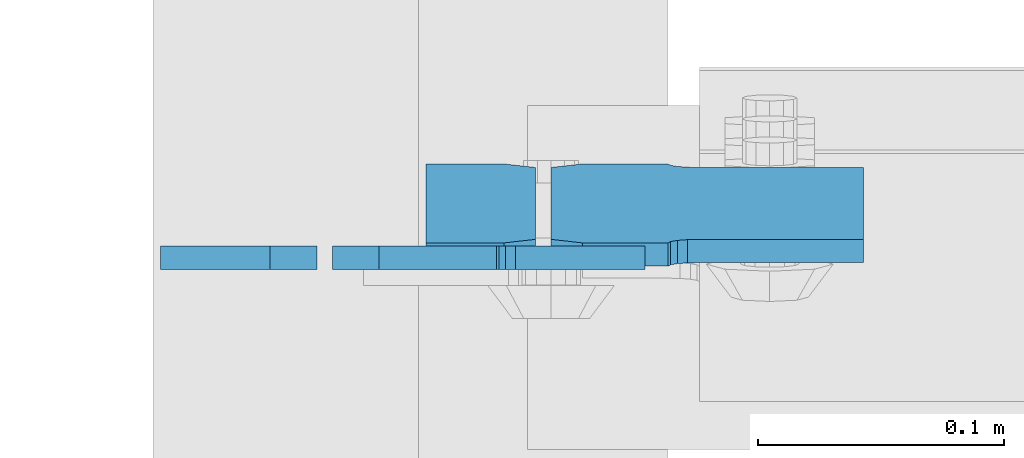
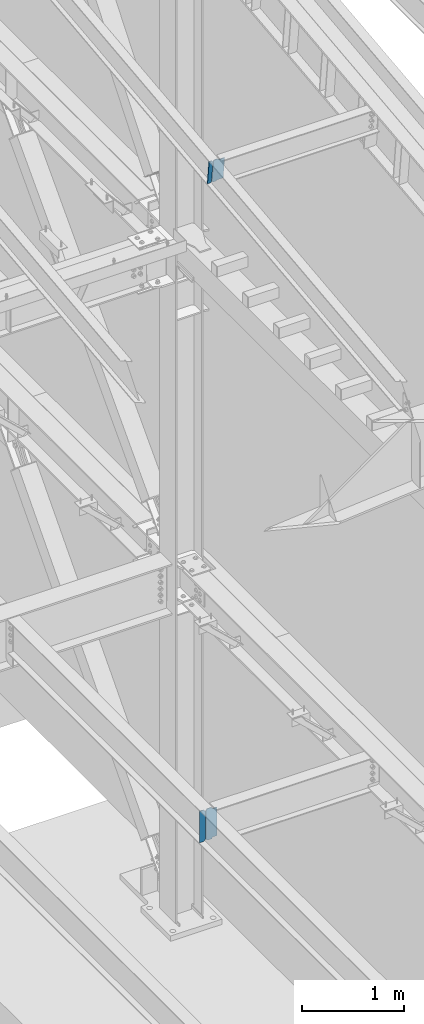
# One storey, part 1036 of 1179: 4 plates, 2 elements without a shape of their own.
"""IFC2X3 building model written with IfcOpenShell, lengths in millimetres."""

from ifc_helpers import new_model, si_unit, frame, origin_with_axes, place, context, subcontext, project, spatial, faceted_brep, material, type_object, element, aggregate, save


model = new_model("IFC2X3")

# Units and contexts
model_context = context("Model", 3, precision=1e-05, world=origin_with_axes())
body_context = subcontext(model_context, "Body", "Model", "MODEL_VIEW")
ifc_project = project(units=[si_unit("LENGTHUNIT", "METRE", prefix="MILLI"), si_unit("AREAUNIT", "SQUARE_METRE"), si_unit("VOLUMEUNIT", "CUBIC_METRE"), si_unit("MASSUNIT", "GRAM", prefix="KILO"), si_unit("TIMEUNIT", "SECOND"), si_unit("PLANEANGLEUNIT", "RADIAN"), si_unit("SOLIDANGLEUNIT", "STERADIAN"), si_unit("THERMODYNAMICTEMPERATUREUNIT", "DEGREE_CELSIUS"), si_unit("LUMINOUSINTENSITYUNIT", "LUMEN")], contexts=[model_context])

# Site, building, storey
site_placement = place(None, origin_with_axes())
site = spatial("IfcSite", under=ifc_project, at=site_placement, CompositionType="ELEMENT")
building_placement = place(site_placement, origin_with_axes())
building = spatial("IfcBuilding", under=site, at=building_placement, Name="Undefined", CompositionType="ELEMENT")
storey_placement = place(building_placement, origin_with_axes())
storey = spatial("IfcBuildingStorey", under=building, at=storey_placement, Name="Undefined", CompositionType="ELEMENT", Elevation=0.0)

# Assembly, plates
assembly_1_placement = place(storey_placement, origin_with_axes())
assembly_1 = element("IfcElementAssembly", 1, at=assembly_1_placement, inside=storey, Name="BEAM", AssemblyPlace="NOTDEFINED", PredefinedType="RIGID_FRAME")
ifc_material = material(Name="STEEL/A36")
plate_type_1 = type_object("IfcPlateType", PredefinedType="NOTDEFINED")
plate_1_placement = place(assembly_1_placement, frame((22412.325, 23180.8083222494, 11565.9313643572), z_axis=(0.0, -0.112284087038017, 0.993676146336441), x_axis=(-1.0, 0.0, 0.0)))
plate_1 = element("IfcPlate", 2, at=plate_1_placement, type_object=plate_type_1, material=ifc_material, Name="PLATE", context=body_context, shape_type="Brep", body=[
    faceted_brep([(-2.72848410531878e-12, -4.76249999998981, 12.6999998092615), (-5.54791768081486e-11, -4.76249999988249, 273.050000190095), (-5.54791768081486e-11, 4.76250000010987, 273.050000190089), (-2.72848410531878e-12, 4.76250000000437, 12.699999809256), (12.6999998092069, -4.76249999987886, 285.749999999351), (12.6999998092069, 4.76250000011532, 285.749999999349), (44.450000005796, -4.76249999988067, 285.749999998694), (44.450000005796, 4.7625000001135, 285.74999999869), (44.4500000000007, -4.76250000000073, 0.0), (44.4500000000007, 4.76250000000073, 0.0), (12.6999998092651, -4.76249999999527, 1.81898940354586e-12), (12.6999998092651, 4.76250000000073, 0.0)], [[[0, 1, 2, 3]], [[1, 4, 5, 2]], [[4, 6, 7, 5]], [[6, 8, 9, 7]], [[8, 10, 11, 9]], [[10, 0, 3, 11]], [[5, 7, 9, 11, 3, 2]], [[10, 8, 6, 4, 1, 0]]]),
])
plate_type_2 = type_object("IfcPlateType", PredefinedType="NOTDEFINED")
plate_2_placement = place(assembly_1_placement, frame((22418.675, 23148.7226475766, 11849.8742670331), z_axis=(1.0, 0.0, 0.0), x_axis=(0.0, 0.112284087038014, -0.993676146336441)))
plate_2 = element("IfcPlate", 3, at=plate_2_placement, type_object=plate_type_2, material=ifc_material, Name="PLATE", context=body_context, shape_type="Brep", body=[
    faceted_brep([(273.049999995341, -4.76249999988795, 127.0), (273.049999995888, -4.76249999988795, 60.3249998091615), (273.049999995885, 4.76250000010623, 60.3249998091615), (273.049999995339, 4.76250000010623, 127.0), (274.016729918505, -4.76249999988795, 55.4649202911478), (274.0167299185, 4.76250000010623, 55.4649202911478), (276.769743818986, -4.76249999988795, 51.3447438230296), (276.769743818983, 4.76250000010623, 51.3447438230296), (280.889920287118, -4.76249999988431, 48.5917299225785), (280.889920287116, 4.76250000010987, 48.5917299225785), (285.749999805133, -4.76249999988431, 47.6250000000005), (285.749999999514, 4.7625000001135, 47.6250000000005), (12.6999999979416, -4.76249999999345, 127.0), (12.699999997938, 4.76250000000073, 127.0), (12.699999997998, 4.76250000000073, 60.324999809277), (12.6999999980017, -4.76249999999345, 60.324999809277), (11.7332700754141, 4.76250000000073, 55.4649202912278), (11.7332700754177, -4.76249999999345, 55.4649202912278), (8.98025617494022, 4.76249999999709, 51.3447438230705), (8.98025617494568, -4.76249999999345, 51.3447438230705), (4.86007970679384, 4.76249999999709, 48.5917299225894), (4.8600797067993, -4.76249999999709, 48.5917299225894), (-3.63797880709171e-12, 4.76249999999709, 47.6250000000005), (0.0, -4.76250000000073, 47.6250000000005), (-2.72848410531878e-12, 4.76250000000437, 12.699999809256), (-2.72848410531878e-12, -4.76249999998981, 12.6999998092615), (12.6999998092651, -4.76249999999527, 1.81898940354586e-12), (12.6999998092651, 4.76250000000073, 0.0), (273.050000190497, -4.76249999988977, -5.59339241590351e-11), (273.050000190493, 4.76250000010623, -5.59339241590351e-11), (285.749999999753, -4.76249999988249, 12.6999998092065), (285.749999999747, 4.76250000011169, 12.6999998092065)], [[[0, 1, 2, 3]], [[4, 5, 2, 1]], [[6, 7, 5, 4]], [[8, 9, 7, 6]], [[10, 11, 9, 8]], [[12, 13, 14, 15]], [[15, 14, 16, 17]], [[17, 16, 18, 19]], [[19, 18, 20, 21]], [[21, 20, 22, 23]], [[24, 25, 23, 22]], [[26, 25, 24, 27]], [[28, 26, 27, 29]], [[30, 28, 29, 31]], [[6, 4, 1, 0, 12, 15, 17, 19, 21, 23, 25, 26, 28, 30, 10, 8]], [[13, 12, 0, 3]], [[31, 29, 27, 24, 22, 20, 18, 16, 14, 13, 3, 2, 5, 7, 9, 11]], [[30, 31, 11, 10]]]),
])
aggregate(assembly_1, [plate_1, plate_2])

assembly_2_placement = place(storey_placement, origin_with_axes())
assembly_2 = element("IfcElementAssembly", 4, at=assembly_2_placement, inside=storey, Name="BEAM", AssemblyPlace="NOTDEFINED", PredefinedType="RIGID_FRAME")
plate_3_placement = place(assembly_2_placement, frame((22329.775, 23147.3379999161, 3711.575), z_axis=(0.0, 0.0, 1.0), x_axis=(1.0, 0.0, 0.0)))
plate_3 = element("IfcPlate", 5, at=plate_3_placement, type_object=plate_type_2, material=ifc_material, Name="PLATE", context=body_context, shape_type="Brep", body=[
    faceted_brep([(66.6760135000841, -4.76250000000073, 0.0), (66.6760161004204, 4.76250000000073, 0.0), (66.6760161004204, 4.76250000000073, 6.35000095367513), (66.6760135000841, -4.76250000000073, 6.35000095367513), (67.6427460230079, 4.76250000000073, 11.2100804717206), (67.6427434226716, -4.76250000000073, 11.2100804717206), (70.3957599234891, 4.76250000000073, 15.3302569398738), (70.3957573231492, -4.76250000000073, 15.3302569398738), (74.5159363916428, 4.76250000000073, 18.0832708403518), (74.5159337913065, -4.76250000000073, 18.0832708403518), (79.3760159096855, 4.76250000000073, 19.0500007629394), (79.3760133093492, -4.76250000000073, 19.0500007629394), (127.000004868059, -4.76250000000073, 19.0500000145084), (127.000004873054, 4.76250000000073, 19.0500000145084), (19.0499992370605, -4.76250000000073, 0.0), (0.0, -4.76250000000073, 19.0499992370605), (0.0, 4.76250000000073, 19.0499992370605), (19.0499992370605, 4.76250000000073, 0.0), (0.0, -4.76249999999709, 358.775000762939), (0.0, 4.76249999999709, 358.775000762939), (19.0499992370605, -4.76249999999709, 377.825), (19.0499992370605, 4.76249999999709, 377.825), (66.676020440379, -4.76250000000073, 377.825), (66.6760230406981, 4.76250000000073, 377.825), (66.676020440374, -4.76250000000073, 371.474999046325), (66.6760230406976, 4.76250000000073, 371.474999046325), (67.642750362962, -4.76250000000073, 366.614919528279), (67.6427529632856, 4.76250000000073, 366.614919528279), (70.3957642634405, -4.76250000000073, 362.494743060126), (70.395766863764, 4.76250000000073, 362.494743060126), (74.5159407315941, -4.76250000000073, 359.741729159648), (74.5159433319177, 4.76250000000073, 359.741729159648), (79.3760202496401, -4.76250000000073, 358.77499923706), (79.3760228499636, 4.76250000000073, 358.77499923706), (127.000000004868, -4.76249999999709, 358.774999992755), (127.0, 4.76249999999709, 358.774999992755)], [[[0, 1, 2, 3]], [[3, 2, 4, 5]], [[5, 4, 6, 7]], [[7, 6, 8, 9]], [[9, 8, 10, 11]], [[12, 11, 10, 13]], [[14, 15, 16, 17]], [[15, 18, 19, 16]], [[18, 20, 21, 19]], [[21, 20, 22, 23]], [[22, 24, 25, 23]], [[26, 27, 25, 24]], [[28, 29, 27, 26]], [[30, 31, 29, 28]], [[32, 33, 31, 30]], [[34, 35, 33, 32]], [[35, 34, 12, 13]], [[8, 6, 4, 2, 1, 17, 16, 19, 21, 23, 25, 27, 29, 31, 33, 35, 13, 10]], [[14, 17, 1, 0]], [[34, 32, 30, 28, 26, 24, 22, 20, 18, 15, 14, 0, 3, 5, 7, 9, 11, 12]]]),
])
plate_type_3 = type_object("IfcPlateType", PredefinedType="NOTDEFINED")
plate_4_placement = place(assembly_2_placement, frame((22323.425, 23147.3379999161, 3711.575), z_axis=(0.0, 0.0, 1.0), x_axis=(-1.0, 0.0, 0.0)))
plate_4 = element("IfcPlate", 6, at=plate_4_placement, type_object=plate_type_3, material=ifc_material, Name="PLATE", context=body_context, shape_type="Brep", body=[
    faceted_brep([(0.0, -4.76250000000073, 19.0499992370605), (0.0, -4.76249999999709, 358.775000762939), (0.0, 4.76249999999709, 358.775000762939), (0.0, 4.76250000000073, 19.0499992370605), (19.0499992370605, -4.76249999999709, 377.825), (19.0499992370605, 4.76249999999709, 377.825), (63.5, -4.76250000000073, 377.825012207031), (63.5, 4.76250000000073, 377.825012207031), (63.5, -4.76250000000073, 0.0), (63.5, 4.76250000000073, 0.0), (19.0499992370605, -4.76250000000073, 0.0), (19.0499992370605, 4.76250000000073, 0.0)], [[[0, 1, 2, 3]], [[1, 4, 5, 2]], [[4, 6, 7, 5]], [[6, 8, 9, 7]], [[8, 10, 11, 9]], [[10, 0, 3, 11]], [[5, 7, 9, 11, 3, 2]], [[10, 8, 6, 4, 1, 0]]]),
])
aggregate(assembly_2, [plate_4, plate_3])

save(model, "model.ifc")
